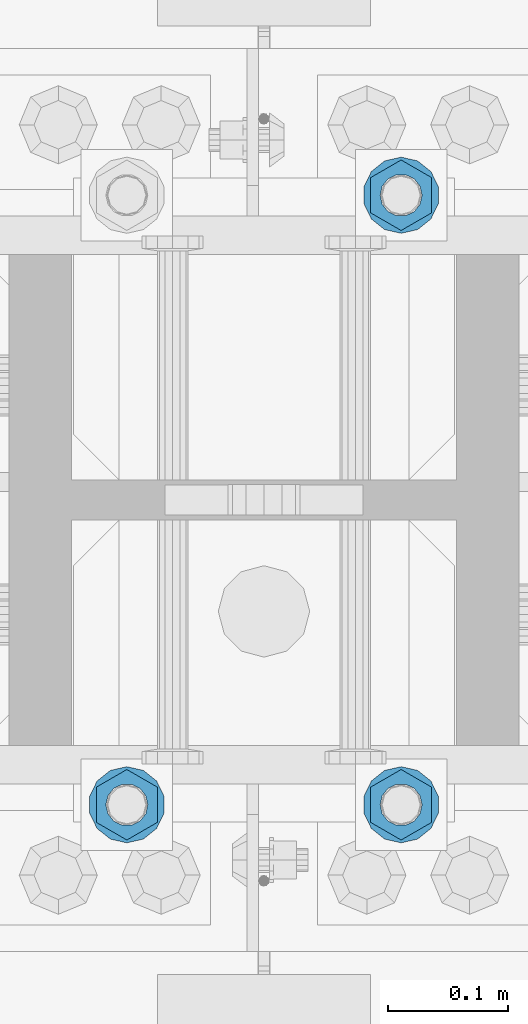
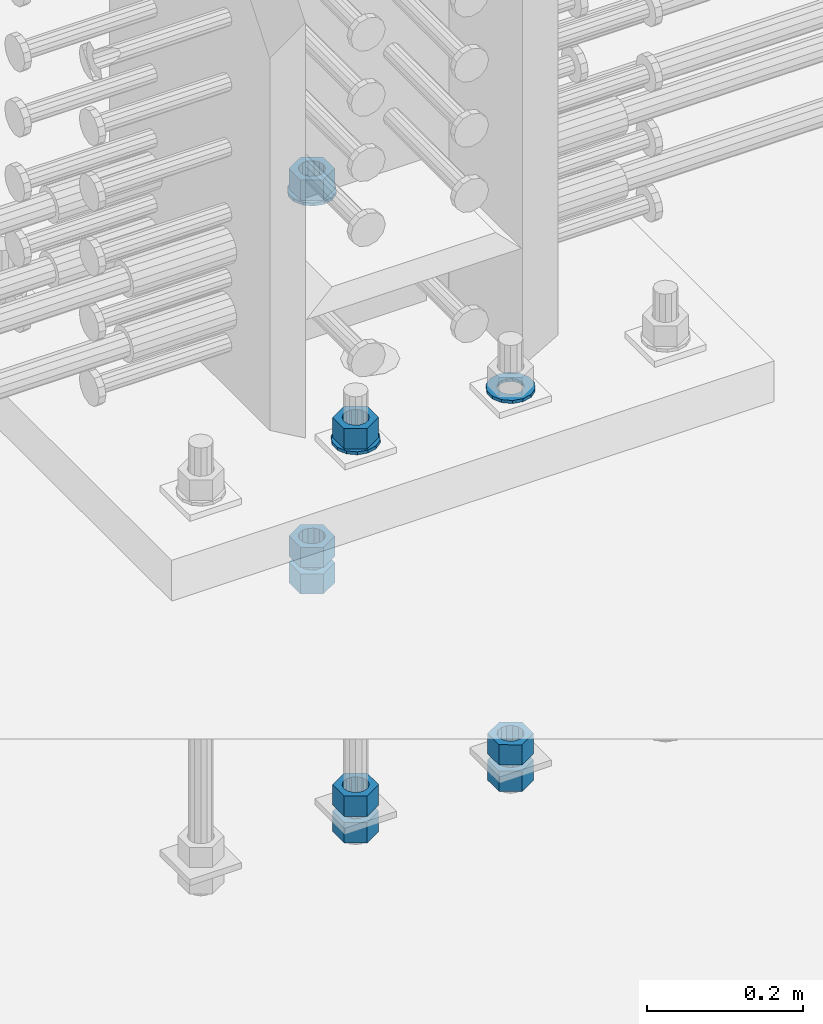
# One storey, part 1000 of 1763: 11 columns, 1 element without a shape of its own.
"""IFC2X3 building model written with IfcOpenShell, lengths in millimetres."""

from ifc_helpers import new_model, si_unit, frame, origin_with_axes, place, context, subcontext, project, spatial, faceted_brep, material, type_object, element, aggregate, save


model = new_model("IFC2X3")

# Units and contexts
model_context = context("Model", 3, precision=1e-05, world=origin_with_axes())
body_context = subcontext(model_context, "Body", "Model", "MODEL_VIEW")
ifc_project = project(units=[si_unit("LENGTHUNIT", "METRE", prefix="MILLI"), si_unit("AREAUNIT", "SQUARE_METRE"), si_unit("VOLUMEUNIT", "CUBIC_METRE"), si_unit("MASSUNIT", "GRAM", prefix="KILO"), si_unit("TIMEUNIT", "SECOND"), si_unit("PLANEANGLEUNIT", "RADIAN"), si_unit("SOLIDANGLEUNIT", "STERADIAN"), si_unit("THERMODYNAMICTEMPERATUREUNIT", "DEGREE_CELSIUS"), si_unit("LUMINOUSINTENSITYUNIT", "LUMEN")], contexts=[model_context])

# Site, building, storey
site_placement = place(None, origin_with_axes())
site = spatial("IfcSite", under=ifc_project, at=site_placement, CompositionType="ELEMENT")
building_placement = place(site_placement, origin_with_axes())
building = spatial("IfcBuilding", under=site, at=building_placement, Name="Undefined", CompositionType="ELEMENT")
storey_placement = place(building_placement, origin_with_axes())
storey = spatial("IfcBuildingStorey", under=building, at=storey_placement, Name="Undefined", CompositionType="ELEMENT", Elevation=0.0)

# Assembly, columns
assembly_placement = place(storey_placement, origin_with_axes())
assembly = element("IfcElementAssembly", 1, at=assembly_placement, inside=storey, Name="TEMPLATE", AssemblyPlace="NOTDEFINED", PredefinedType="RIGID_FRAME")
ifc_material_1 = material(Name="STEEL/A563")
column_type_1 = type_object("IfcColumnType", Name="1-1/4_HEAVY_HEX_NUT", PredefinedType="NOTDEFINED")
column_1_placement = place(assembly_placement, frame((-49288.1372736986, 203.200000000003, 3384.55), z_axis=(1.0, 0.0, 0.0), x_axis=(0.0, 0.0, -1.0)))
column_1 = element("IfcColumn", 2, at=column_1_placement, type_object=column_type_1, material=ifc_material_1, Name="NUT", ObjectType="1-1/4_HEAVY_HEX_NUT", context=body_context, shape_type="Brep", body=[
    faceted_brep([(0.0, -29.3700008392334, 0.0), (0.0, -14.6800003051758, -25.4300003051758), (31.75, -14.6800003051758, -25.4300003051758), (31.75, -29.3700008392334, 0.0), (0.0, 14.6800003051758, -25.4300003051758), (31.75, 14.6800003051758, -25.4300003051758), (0.0, 29.3700008392334, 0.0), (31.75, 29.3700008392334, 0.0), (0.0, 14.6800003051758, 25.4300003051758), (31.75, 14.6800003051758, 25.4300003051758), (0.0, -14.6800003051758, 25.4300003051758), (31.75, -14.6800003051758, 25.4300003051758), (0.0, 0.0, 17.4599990844727), (0.0, 7.57560968776022, 15.730915608714), (31.75, 7.57560968775942, 15.7309156087145), (31.75, 0.0, 17.4599990844727), (0.0, 13.6507769681037, 10.8861313696252), (31.75, 13.6507769681048, 10.8861313696314), (0.0, 17.0222404541215, 3.88521530314756), (31.75, 17.02224045412, 3.88521530315316), (0.0, 17.0222404541215, -3.88521530314756), (31.75, 17.02224045412, -3.88521530315332), (0.0, 13.6507769681037, -10.8861313696252), (31.75, 13.6507769681048, -10.8861313696316), (0.0, 7.57560968776022, -15.730915608714), (31.75, 7.57560968775942, -15.7309156087146), (0.0, 0.0, -17.4599990844727), (31.75, 0.0, -17.4599990844727), (0.0, -7.57560968776022, -15.730915608714), (31.75, -7.57560968775942, -15.7309156087145), (0.0, -13.6507769681037, -10.8861313696252), (31.75, -13.6507769681048, -10.8861313696314), (0.0, -17.0222404541215, -3.88521530314756), (31.75, -17.02224045412, -3.88521530315316), (0.0, -17.0222404541215, 3.88521530314756), (31.75, -17.02224045412, 3.88521530315332), (0.0, -13.6507769681037, 10.8861313696252), (31.75, -13.6507769681048, 10.8861313696316), (0.0, -7.57560968776022, 15.730915608714), (31.75, -7.57560968775942, 15.7309156087146)], [[[0, 1, 2, 3]], [[1, 4, 5, 2]], [[4, 6, 7, 5]], [[6, 8, 9, 7]], [[8, 10, 11, 9]], [[10, 0, 3, 11]], [[12, 13, 14, 15]], [[13, 16, 17, 14]], [[16, 18, 19, 17]], [[18, 20, 21, 19]], [[20, 22, 23, 21]], [[22, 24, 25, 23]], [[24, 26, 27, 25]], [[26, 28, 29, 27]], [[28, 30, 31, 29]], [[30, 32, 33, 31]], [[32, 34, 35, 33]], [[34, 36, 37, 35]], [[36, 38, 39, 37]], [[38, 12, 15, 39]], [[5, 7, 9, 11, 3, 2], [17, 19, 21, 23, 25, 27, 29, 31, 33, 35, 37, 39, 15, 14]], [[10, 8, 6, 4, 1, 0], [38, 36, 34, 32, 30, 28, 26, 24, 22, 20, 18, 16, 13, 12]]]),
])
column_2_placement = place(assembly_placement, frame((-49288.1372736986, 203.200000000003, 3343.275), z_axis=(1.0, 0.0, 0.0), x_axis=(0.0, 0.0, -1.0)))
column_2 = element("IfcColumn", 3, at=column_2_placement, type_object=column_type_1, material=ifc_material_1, Name="NUT", ObjectType="1-1/4_HEAVY_HEX_NUT", context=body_context, shape_type="Brep", body=[
    faceted_brep([(0.0, -29.3700008392334, 0.0), (0.0, -14.6800003051758, -25.4300003051758), (31.75, -14.6800003051758, -25.4300003051758), (31.75, -29.3700008392334, 0.0), (0.0, 14.6800003051758, -25.4300003051758), (31.75, 14.6800003051758, -25.4300003051758), (0.0, 29.3700008392334, 0.0), (31.75, 29.3700008392334, 0.0), (0.0, 14.6800003051758, 25.4300003051758), (31.75, 14.6800003051758, 25.4300003051758), (0.0, -14.6800003051758, 25.4300003051758), (31.75, -14.6800003051758, 25.4300003051758), (0.0, 0.0, 17.4599990844727), (0.0, 7.57560968776022, 15.730915608714), (31.75, 7.57560968775942, 15.7309156087145), (31.75, 0.0, 17.4599990844727), (0.0, 13.6507769681037, 10.8861313696252), (31.75, 13.6507769681048, 10.8861313696314), (0.0, 17.0222404541215, 3.88521530314756), (31.75, 17.02224045412, 3.88521530315316), (0.0, 17.0222404541215, -3.88521530314756), (31.75, 17.02224045412, -3.88521530315332), (0.0, 13.6507769681037, -10.8861313696252), (31.75, 13.6507769681048, -10.8861313696316), (0.0, 7.57560968776022, -15.730915608714), (31.75, 7.57560968775942, -15.7309156087146), (0.0, 0.0, -17.4599990844727), (31.75, 0.0, -17.4599990844727), (0.0, -7.57560968776022, -15.730915608714), (31.75, -7.57560968775942, -15.7309156087145), (0.0, -13.6507769681037, -10.8861313696252), (31.75, -13.6507769681048, -10.8861313696314), (0.0, -17.0222404541215, -3.88521530314756), (31.75, -17.02224045412, -3.88521530315316), (0.0, -17.0222404541215, 3.88521530314756), (31.75, -17.02224045412, 3.88521530315332), (0.0, -13.6507769681037, 10.8861313696252), (31.75, -13.6507769681048, 10.8861313696316), (0.0, -7.57560968776022, 15.730915608714), (31.75, -7.57560968775942, 15.7309156087146)], [[[0, 1, 2, 3]], [[1, 4, 5, 2]], [[4, 6, 7, 5]], [[6, 8, 9, 7]], [[8, 10, 11, 9]], [[10, 0, 3, 11]], [[12, 13, 14, 15]], [[13, 16, 17, 14]], [[16, 18, 19, 17]], [[18, 20, 21, 19]], [[20, 22, 23, 21]], [[22, 24, 25, 23]], [[24, 26, 27, 25]], [[26, 28, 29, 27]], [[28, 30, 31, 29]], [[30, 32, 33, 31]], [[32, 34, 35, 33]], [[34, 36, 37, 35]], [[36, 38, 39, 37]], [[38, 12, 15, 39]], [[5, 7, 9, 11, 3, 2], [17, 19, 21, 23, 25, 27, 29, 31, 33, 35, 37, 39, 15, 14]], [[10, 8, 6, 4, 1, 0], [38, 36, 34, 32, 30, 28, 26, 24, 22, 20, 18, 16, 13, 12]]]),
])
column_3_placement = place(assembly_placement, frame((-49288.1372736986, 711.200000000003, 3957.6375), z_axis=(-1.0, 0.0, 0.0), x_axis=(0.0, 0.0, -1.0)))
column_3 = element("IfcColumn", 4, at=column_3_placement, type_object=column_type_1, material=ifc_material_1, Name="NUT", ObjectType="1-1/4_HEAVY_HEX_NUT", context=body_context, shape_type="Brep", body=[
    faceted_brep([(0.0, -29.3700008392334, 0.0), (0.0, -14.6800003051758, -25.4300003051758), (31.75, -14.6800003051758, -25.4300003051758), (31.75, -29.3700008392334, 0.0), (0.0, 14.6800003051758, -25.4300003051758), (31.75, 14.6800003051758, -25.4300003051758), (0.0, 29.3700008392334, 0.0), (31.75, 29.3700008392334, 0.0), (0.0, 14.6800003051758, 25.4300003051758), (31.75, 14.6800003051758, 25.4300003051758), (0.0, -14.6800003051758, 25.4300003051758), (31.75, -14.6800003051758, 25.4300003051758), (0.0, 0.0, 17.4599990844727), (0.0, 7.57560968776022, 15.730915608714), (31.75, 7.57560968775942, 15.7309156087145), (31.75, 0.0, 17.4599990844727), (0.0, 13.6507769681037, 10.8861313696252), (31.75, 13.6507769681048, 10.8861313696314), (0.0, 17.0222404541215, 3.88521530314756), (31.75, 17.02224045412, 3.88521530315316), (0.0, 17.0222404541215, -3.88521530314756), (31.75, 17.02224045412, -3.88521530315332), (0.0, 13.6507769681037, -10.8861313696252), (31.75, 13.6507769681048, -10.8861313696316), (0.0, 7.57560968776022, -15.730915608714), (31.75, 7.57560968775942, -15.7309156087146), (0.0, 0.0, -17.4599990844727), (31.75, 0.0, -17.4599990844727), (0.0, -7.57560968776022, -15.730915608714), (31.75, -7.57560968775942, -15.7309156087145), (0.0, -13.6507769681037, -10.8861313696252), (31.75, -13.6507769681048, -10.8861313696314), (0.0, -17.0222404541215, -3.88521530314756), (31.75, -17.02224045412, -3.88521530315316), (0.0, -17.0222404541215, 3.88521530314756), (31.75, -17.02224045412, 3.88521530315332), (0.0, -13.6507769681037, 10.8861313696252), (31.75, -13.6507769681048, 10.8861313696316), (0.0, -7.57560968776022, 15.730915608714), (31.75, -7.57560968775942, 15.7309156087146)], [[[0, 1, 2, 3]], [[1, 4, 5, 2]], [[4, 6, 7, 5]], [[6, 8, 9, 7]], [[8, 10, 11, 9]], [[10, 0, 3, 11]], [[12, 13, 14, 15]], [[13, 16, 17, 14]], [[16, 18, 19, 17]], [[18, 20, 21, 19]], [[20, 22, 23, 21]], [[22, 24, 25, 23]], [[24, 26, 27, 25]], [[26, 28, 29, 27]], [[28, 30, 31, 29]], [[30, 32, 33, 31]], [[32, 34, 35, 33]], [[34, 36, 37, 35]], [[36, 38, 39, 37]], [[38, 12, 15, 39]], [[5, 7, 9, 11, 3, 2], [17, 19, 21, 23, 25, 27, 29, 31, 33, 35, 37, 39, 15, 14]], [[10, 8, 6, 4, 1, 0], [38, 36, 34, 32, 30, 28, 26, 24, 22, 20, 18, 16, 13, 12]]]),
])
column_4_placement = place(assembly_placement, frame((-49288.1372736986, 711.200000000003, 3384.55), z_axis=(-1.0, 0.0, 0.0), x_axis=(0.0, 0.0, -1.0)))
column_4 = element("IfcColumn", 5, at=column_4_placement, type_object=column_type_1, material=ifc_material_1, Name="NUT", ObjectType="1-1/4_HEAVY_HEX_NUT", context=body_context, shape_type="Brep", body=[
    faceted_brep([(0.0, -29.3700008392334, 0.0), (0.0, -14.6800003051758, -25.4300003051758), (31.75, -14.6800003051758, -25.4300003051758), (31.75, -29.3700008392334, 0.0), (0.0, 14.6800003051758, -25.4300003051758), (31.75, 14.6800003051758, -25.4300003051758), (0.0, 29.3700008392334, 0.0), (31.75, 29.3700008392334, 0.0), (0.0, 14.6800003051758, 25.4300003051758), (31.75, 14.6800003051758, 25.4300003051758), (0.0, -14.6800003051758, 25.4300003051758), (31.75, -14.6800003051758, 25.4300003051758), (0.0, 0.0, 17.4599990844727), (0.0, 7.57560968776022, 15.730915608714), (31.75, 7.57560968775942, 15.7309156087145), (31.75, 0.0, 17.4599990844727), (0.0, 13.6507769681037, 10.8861313696252), (31.75, 13.6507769681048, 10.8861313696314), (0.0, 17.0222404541215, 3.88521530314756), (31.75, 17.02224045412, 3.88521530315316), (0.0, 17.0222404541215, -3.88521530314756), (31.75, 17.02224045412, -3.88521530315332), (0.0, 13.6507769681037, -10.8861313696252), (31.75, 13.6507769681048, -10.8861313696316), (0.0, 7.57560968776022, -15.730915608714), (31.75, 7.57560968775942, -15.7309156087146), (0.0, 0.0, -17.4599990844727), (31.75, 0.0, -17.4599990844727), (0.0, -7.57560968776022, -15.730915608714), (31.75, -7.57560968775942, -15.7309156087145), (0.0, -13.6507769681037, -10.8861313696252), (31.75, -13.6507769681048, -10.8861313696314), (0.0, -17.0222404541215, -3.88521530314756), (31.75, -17.02224045412, -3.88521530315316), (0.0, -17.0222404541215, 3.88521530314756), (31.75, -17.02224045412, 3.88521530315332), (0.0, -13.6507769681037, 10.8861313696252), (31.75, -13.6507769681048, 10.8861313696316), (0.0, -7.57560968776022, 15.730915608714), (31.75, -7.57560968775942, 15.7309156087146)], [[[0, 1, 2, 3]], [[1, 4, 5, 2]], [[4, 6, 7, 5]], [[6, 8, 9, 7]], [[8, 10, 11, 9]], [[10, 0, 3, 11]], [[12, 13, 14, 15]], [[13, 16, 17, 14]], [[16, 18, 19, 17]], [[18, 20, 21, 19]], [[20, 22, 23, 21]], [[22, 24, 25, 23]], [[24, 26, 27, 25]], [[26, 28, 29, 27]], [[28, 30, 31, 29]], [[30, 32, 33, 31]], [[32, 34, 35, 33]], [[34, 36, 37, 35]], [[36, 38, 39, 37]], [[38, 12, 15, 39]], [[5, 7, 9, 11, 3, 2], [17, 19, 21, 23, 25, 27, 29, 31, 33, 35, 37, 39, 15, 14]], [[10, 8, 6, 4, 1, 0], [38, 36, 34, 32, 30, 28, 26, 24, 22, 20, 18, 16, 13, 12]]]),
])
column_5_placement = place(assembly_placement, frame((-49288.1372736986, 711.200000000003, 3343.275), z_axis=(-1.0, 0.0, 0.0), x_axis=(0.0, 0.0, -1.0)))
column_5 = element("IfcColumn", 6, at=column_5_placement, type_object=column_type_1, material=ifc_material_1, Name="NUT", ObjectType="1-1/4_HEAVY_HEX_NUT", context=body_context, shape_type="Brep", body=[
    faceted_brep([(0.0, -29.3700008392334, 0.0), (0.0, -14.6800003051758, -25.4300003051758), (31.75, -14.6800003051758, -25.4300003051758), (31.75, -29.3700008392334, 0.0), (0.0, 14.6800003051758, -25.4300003051758), (31.75, 14.6800003051758, -25.4300003051758), (0.0, 29.3700008392334, 0.0), (31.75, 29.3700008392334, 0.0), (0.0, 14.6800003051758, 25.4300003051758), (31.75, 14.6800003051758, 25.4300003051758), (0.0, -14.6800003051758, 25.4300003051758), (31.75, -14.6800003051758, 25.4300003051758), (0.0, 0.0, 17.4599990844727), (0.0, 7.57560968776022, 15.730915608714), (31.75, 7.57560968775942, 15.7309156087145), (31.75, 0.0, 17.4599990844727), (0.0, 13.6507769681037, 10.8861313696252), (31.75, 13.6507769681048, 10.8861313696314), (0.0, 17.0222404541215, 3.88521530314756), (31.75, 17.02224045412, 3.88521530315316), (0.0, 17.0222404541215, -3.88521530314756), (31.75, 17.02224045412, -3.88521530315332), (0.0, 13.6507769681037, -10.8861313696252), (31.75, 13.6507769681048, -10.8861313696316), (0.0, 7.57560968776022, -15.730915608714), (31.75, 7.57560968775942, -15.7309156087146), (0.0, 0.0, -17.4599990844727), (31.75, 0.0, -17.4599990844727), (0.0, -7.57560968776022, -15.730915608714), (31.75, -7.57560968775942, -15.7309156087145), (0.0, -13.6507769681037, -10.8861313696252), (31.75, -13.6507769681048, -10.8861313696314), (0.0, -17.0222404541215, -3.88521530314756), (31.75, -17.02224045412, -3.88521530315316), (0.0, -17.0222404541215, 3.88521530314756), (31.75, -17.02224045412, 3.88521530315332), (0.0, -13.6507769681037, 10.8861313696252), (31.75, -13.6507769681048, 10.8861313696316), (0.0, -7.57560968776022, 15.730915608714), (31.75, -7.57560968775942, 15.7309156087146)], [[[0, 1, 2, 3]], [[1, 4, 5, 2]], [[4, 6, 7, 5]], [[6, 8, 9, 7]], [[8, 10, 11, 9]], [[10, 0, 3, 11]], [[12, 13, 14, 15]], [[13, 16, 17, 14]], [[16, 18, 19, 17]], [[18, 20, 21, 19]], [[20, 22, 23, 21]], [[22, 24, 25, 23]], [[24, 26, 27, 25]], [[26, 28, 29, 27]], [[28, 30, 31, 29]], [[30, 32, 33, 31]], [[32, 34, 35, 33]], [[34, 36, 37, 35]], [[36, 38, 39, 37]], [[38, 12, 15, 39]], [[5, 7, 9, 11, 3, 2], [17, 19, 21, 23, 25, 27, 29, 31, 33, 35, 37, 39, 15, 14]], [[10, 8, 6, 4, 1, 0], [38, 36, 34, 32, 30, 28, 26, 24, 22, 20, 18, 16, 13, 12]]]),
])
column_6_placement = place(assembly_placement, frame((-49516.7372736986, 203.200000000003, 3957.6375), z_axis=(1.0, 0.0, 0.0), x_axis=(0.0, 0.0, -1.0)))
column_6 = element("IfcColumn", 7, at=column_6_placement, type_object=column_type_1, material=ifc_material_1, Name="NUT", ObjectType="1-1/4_HEAVY_HEX_NUT", context=body_context, shape_type="Brep", body=[
    faceted_brep([(0.0, -29.3700008392334, 0.0), (0.0, -14.6800003051758, -25.4300003051758), (31.75, -14.6800003051758, -25.4300003051758), (31.75, -29.3700008392334, 0.0), (0.0, 14.6800003051758, -25.4300003051758), (31.75, 14.6800003051758, -25.4300003051758), (0.0, 29.3700008392334, 0.0), (31.75, 29.3700008392334, 0.0), (0.0, 14.6800003051758, 25.4300003051758), (31.75, 14.6800003051758, 25.4300003051758), (0.0, -14.6800003051758, 25.4300003051758), (31.75, -14.6800003051758, 25.4300003051758), (0.0, 0.0, 17.4599990844727), (0.0, 7.57560968776022, 15.730915608714), (31.75, 7.57560968775942, 15.7309156087145), (31.75, 0.0, 17.4599990844727), (0.0, 13.6507769681037, 10.8861313696252), (31.75, 13.6507769681048, 10.8861313696314), (0.0, 17.0222404541215, 3.88521530314756), (31.75, 17.02224045412, 3.88521530315316), (0.0, 17.0222404541215, -3.88521530314756), (31.75, 17.02224045412, -3.88521530315332), (0.0, 13.6507769681037, -10.8861313696252), (31.75, 13.6507769681048, -10.8861313696316), (0.0, 7.57560968776022, -15.730915608714), (31.75, 7.57560968775942, -15.7309156087146), (0.0, 0.0, -17.4599990844727), (31.75, 0.0, -17.4599990844727), (0.0, -7.57560968776022, -15.730915608714), (31.75, -7.57560968775942, -15.7309156087145), (0.0, -13.6507769681037, -10.8861313696252), (31.75, -13.6507769681048, -10.8861313696314), (0.0, -17.0222404541215, -3.88521530314756), (31.75, -17.02224045412, -3.88521530315316), (0.0, -17.0222404541215, 3.88521530314756), (31.75, -17.02224045412, 3.88521530315332), (0.0, -13.6507769681037, 10.8861313696252), (31.75, -13.6507769681048, 10.8861313696316), (0.0, -7.57560968776022, 15.730915608714), (31.75, -7.57560968775942, 15.7309156087146)], [[[0, 1, 2, 3]], [[1, 4, 5, 2]], [[4, 6, 7, 5]], [[6, 8, 9, 7]], [[8, 10, 11, 9]], [[10, 0, 3, 11]], [[12, 13, 14, 15]], [[13, 16, 17, 14]], [[16, 18, 19, 17]], [[18, 20, 21, 19]], [[20, 22, 23, 21]], [[22, 24, 25, 23]], [[24, 26, 27, 25]], [[26, 28, 29, 27]], [[28, 30, 31, 29]], [[30, 32, 33, 31]], [[32, 34, 35, 33]], [[34, 36, 37, 35]], [[36, 38, 39, 37]], [[38, 12, 15, 39]], [[5, 7, 9, 11, 3, 2], [17, 19, 21, 23, 25, 27, 29, 31, 33, 35, 37, 39, 15, 14]], [[10, 8, 6, 4, 1, 0], [38, 36, 34, 32, 30, 28, 26, 24, 22, 20, 18, 16, 13, 12]]]),
])
column_7_placement = place(assembly_placement, frame((-49516.7372736986, 203.200000000003, 3384.55), z_axis=(1.0, 0.0, 0.0), x_axis=(0.0, 0.0, -1.0)))
column_7 = element("IfcColumn", 8, at=column_7_placement, type_object=column_type_1, material=ifc_material_1, Name="NUT", ObjectType="1-1/4_HEAVY_HEX_NUT", context=body_context, shape_type="Brep", body=[
    faceted_brep([(0.0, -29.3700008392334, 0.0), (0.0, -14.6800003051758, -25.4300003051758), (31.75, -14.6800003051758, -25.4300003051758), (31.75, -29.3700008392334, 0.0), (0.0, 14.6800003051758, -25.4300003051758), (31.75, 14.6800003051758, -25.4300003051758), (0.0, 29.3700008392334, 0.0), (31.75, 29.3700008392334, 0.0), (0.0, 14.6800003051758, 25.4300003051758), (31.75, 14.6800003051758, 25.4300003051758), (0.0, -14.6800003051758, 25.4300003051758), (31.75, -14.6800003051758, 25.4300003051758), (0.0, 0.0, 17.4599990844727), (0.0, 7.57560968776022, 15.730915608714), (31.75, 7.57560968775942, 15.7309156087145), (31.75, 0.0, 17.4599990844727), (0.0, 13.6507769681037, 10.8861313696252), (31.75, 13.6507769681048, 10.8861313696314), (0.0, 17.0222404541215, 3.88521530314756), (31.75, 17.02224045412, 3.88521530315316), (0.0, 17.0222404541215, -3.88521530314756), (31.75, 17.02224045412, -3.88521530315332), (0.0, 13.6507769681037, -10.8861313696252), (31.75, 13.6507769681048, -10.8861313696316), (0.0, 7.57560968776022, -15.730915608714), (31.75, 7.57560968775942, -15.7309156087146), (0.0, 0.0, -17.4599990844727), (31.75, 0.0, -17.4599990844727), (0.0, -7.57560968776022, -15.730915608714), (31.75, -7.57560968775942, -15.7309156087145), (0.0, -13.6507769681037, -10.8861313696252), (31.75, -13.6507769681048, -10.8861313696314), (0.0, -17.0222404541215, -3.88521530314756), (31.75, -17.02224045412, -3.88521530315316), (0.0, -17.0222404541215, 3.88521530314756), (31.75, -17.02224045412, 3.88521530315332), (0.0, -13.6507769681037, 10.8861313696252), (31.75, -13.6507769681048, 10.8861313696316), (0.0, -7.57560968776022, 15.730915608714), (31.75, -7.57560968775942, 15.7309156087146)], [[[0, 1, 2, 3]], [[1, 4, 5, 2]], [[4, 6, 7, 5]], [[6, 8, 9, 7]], [[8, 10, 11, 9]], [[10, 0, 3, 11]], [[12, 13, 14, 15]], [[13, 16, 17, 14]], [[16, 18, 19, 17]], [[18, 20, 21, 19]], [[20, 22, 23, 21]], [[22, 24, 25, 23]], [[24, 26, 27, 25]], [[26, 28, 29, 27]], [[28, 30, 31, 29]], [[30, 32, 33, 31]], [[32, 34, 35, 33]], [[34, 36, 37, 35]], [[36, 38, 39, 37]], [[38, 12, 15, 39]], [[5, 7, 9, 11, 3, 2], [17, 19, 21, 23, 25, 27, 29, 31, 33, 35, 37, 39, 15, 14]], [[10, 8, 6, 4, 1, 0], [38, 36, 34, 32, 30, 28, 26, 24, 22, 20, 18, 16, 13, 12]]]),
])
column_8_placement = place(assembly_placement, frame((-49516.7372736986, 203.200000000003, 3343.275), z_axis=(1.0, 0.0, 0.0), x_axis=(0.0, 0.0, -1.0)))
column_8 = element("IfcColumn", 9, at=column_8_placement, type_object=column_type_1, material=ifc_material_1, Name="NUT", ObjectType="1-1/4_HEAVY_HEX_NUT", context=body_context, shape_type="Brep", body=[
    faceted_brep([(0.0, -29.3700008392334, 0.0), (0.0, -14.6800003051758, -25.4300003051758), (31.75, -14.6800003051758, -25.4300003051758), (31.75, -29.3700008392334, 0.0), (0.0, 14.6800003051758, -25.4300003051758), (31.75, 14.6800003051758, -25.4300003051758), (0.0, 29.3700008392334, 0.0), (31.75, 29.3700008392334, 0.0), (0.0, 14.6800003051758, 25.4300003051758), (31.75, 14.6800003051758, 25.4300003051758), (0.0, -14.6800003051758, 25.4300003051758), (31.75, -14.6800003051758, 25.4300003051758), (0.0, 0.0, 17.4599990844727), (0.0, 7.57560968776022, 15.730915608714), (31.75, 7.57560968775942, 15.7309156087145), (31.75, 0.0, 17.4599990844727), (0.0, 13.6507769681037, 10.8861313696252), (31.75, 13.6507769681048, 10.8861313696314), (0.0, 17.0222404541215, 3.88521530314756), (31.75, 17.02224045412, 3.88521530315316), (0.0, 17.0222404541215, -3.88521530314756), (31.75, 17.02224045412, -3.88521530315332), (0.0, 13.6507769681037, -10.8861313696252), (31.75, 13.6507769681048, -10.8861313696316), (0.0, 7.57560968776022, -15.730915608714), (31.75, 7.57560968775942, -15.7309156087146), (0.0, 0.0, -17.4599990844727), (31.75, 0.0, -17.4599990844727), (0.0, -7.57560968776022, -15.730915608714), (31.75, -7.57560968775942, -15.7309156087145), (0.0, -13.6507769681037, -10.8861313696252), (31.75, -13.6507769681048, -10.8861313696314), (0.0, -17.0222404541215, -3.88521530314756), (31.75, -17.02224045412, -3.88521530315316), (0.0, -17.0222404541215, 3.88521530314756), (31.75, -17.02224045412, 3.88521530315332), (0.0, -13.6507769681037, 10.8861313696252), (31.75, -13.6507769681048, 10.8861313696316), (0.0, -7.57560968776022, 15.730915608714), (31.75, -7.57560968775942, 15.7309156087146)], [[[0, 1, 2, 3]], [[1, 4, 5, 2]], [[4, 6, 7, 5]], [[6, 8, 9, 7]], [[8, 10, 11, 9]], [[10, 0, 3, 11]], [[12, 13, 14, 15]], [[13, 16, 17, 14]], [[16, 18, 19, 17]], [[18, 20, 21, 19]], [[20, 22, 23, 21]], [[22, 24, 25, 23]], [[24, 26, 27, 25]], [[26, 28, 29, 27]], [[28, 30, 31, 29]], [[30, 32, 33, 31]], [[32, 34, 35, 33]], [[34, 36, 37, 35]], [[36, 38, 39, 37]], [[38, 12, 15, 39]], [[5, 7, 9, 11, 3, 2], [17, 19, 21, 23, 25, 27, 29, 31, 33, 35, 37, 39, 15, 14]], [[10, 8, 6, 4, 1, 0], [38, 36, 34, 32, 30, 28, 26, 24, 22, 20, 18, 16, 13, 12]]]),
])
ifc_material_2 = material(Name="STEEL/F436")
column_type_2 = type_object("IfcColumnType", Name="1-1/4_WASHER", PredefinedType="NOTDEFINED")
column_9_placement = place(assembly_placement, frame((-49288.1372736986, 203.200000000003, 3925.8875), z_axis=(1.0, 0.0, 0.0), x_axis=(0.0, 0.0, -1.0)))
column_9 = element("IfcColumn", 10, at=column_9_placement, type_object=column_type_2, material=ifc_material_2, Name="WASHER", ObjectType="1-1/4_WASHER", context=body_context, shape_type="Brep", body=[
    faceted_brep([(-4.54747350886464e-13, -31.7499999999964, 0.0), (0.0, -28.6057615559002, -13.7758087169827), (4.76249999999982, -28.6057615559002, -13.7758087169827), (4.76249999999982, -31.75, 0.0), (0.0, -19.795801209013, -24.8231495683602), (4.76249999999982, -19.795801209013, -24.8231495683602), (0.0, -7.06503965311276, -30.9539612117732), (4.76249999999982, -7.06503965311276, -30.9539612117732), (0.0, 7.06503965311276, -30.9539612117732), (4.76249999999982, 7.06503965311276, -30.9539612117732), (0.0, 19.7958012090166, -24.8231495683602), (4.76249999999982, 19.7958012090166, -24.8231495683602), (0.0, 28.6057615559039, -13.7758087169827), (4.76249999999982, 28.6057615559039, -13.7758087169827), (-5.91171556152403e-12, 31.7499999999891, 0.0), (4.76249999999982, 31.75, 0.0), (0.0, 28.6057615559002, 13.7758087169827), (4.76249999999982, 28.6057615559002, 13.7758087169827), (0.0, 19.795801209013, 24.8231495683602), (4.76249999999982, 19.795801209013, 24.8231495683602), (0.0, 7.06503965311276, 30.9539612117731), (4.76249999999982, 7.06503965311276, 30.9539612117731), (0.0, -7.06503965311276, 30.9539612117731), (4.76249999999982, -7.06503965311276, 30.9539612117731), (0.0, -19.7958012090166, 24.8231495683602), (4.76249999999982, -19.7958012090166, 24.8231495683602), (0.0, -28.6057615559039, 13.7758087169827), (4.76249999999982, -28.6057615559039, 13.7758087169827), (0.0, 0.0, 17.4599990844727), (0.0, 7.57560968776022, 15.730915608714), (4.76249999999982, 7.57560968775942, 15.7309156087145), (4.76249999999982, 0.0, 17.4599990844727), (0.0, 13.6507769681037, 10.8861313696252), (4.76249999999982, 13.6507769681048, 10.8861313696314), (0.0, 17.0222404541215, 3.88521530314756), (4.76249999999982, 17.02224045412, 3.88521530315316), (0.0, 17.0222404541215, -3.88521530314756), (4.76249999999982, 17.02224045412, -3.88521530315332), (0.0, 13.6507769681037, -10.8861313696252), (4.76249999999982, 13.6507769681048, -10.8861313696316), (0.0, 7.57560968776022, -15.730915608714), (4.76249999999982, 7.57560968775942, -15.7309156087146), (0.0, 0.0, -17.4599990844727), (4.76249999999982, 0.0, -17.4599990844727), (0.0, -7.57560968776022, -15.730915608714), (4.76249999999982, -7.57560968775942, -15.7309156087145), (0.0, -13.6507769681037, -10.8861313696252), (4.76249999999982, -13.6507769681048, -10.8861313696314), (0.0, -17.0222404541215, -3.88521530314756), (4.76249999999982, -17.02224045412, -3.88521530315316), (0.0, -17.0222404541215, 3.88521530314756), (4.76249999999982, -17.02224045412, 3.88521530315332), (0.0, -13.6507769681037, 10.8861313696252), (4.76249999999982, -13.6507769681048, 10.8861313696316), (0.0, -7.57560968776022, 15.730915608714), (4.76249999999982, -7.57560968775942, 15.7309156087146)], [[[0, 1, 2, 3]], [[1, 4, 5, 2]], [[4, 6, 7, 5]], [[6, 8, 9, 7]], [[8, 10, 11, 9]], [[10, 12, 13, 11]], [[12, 14, 15, 13]], [[14, 16, 17, 15]], [[16, 18, 19, 17]], [[18, 20, 21, 19]], [[20, 22, 23, 21]], [[22, 24, 25, 23]], [[24, 26, 27, 25]], [[26, 0, 3, 27]], [[28, 29, 30, 31]], [[29, 32, 33, 30]], [[32, 34, 35, 33]], [[34, 36, 37, 35]], [[36, 38, 39, 37]], [[38, 40, 41, 39]], [[40, 42, 43, 41]], [[42, 44, 45, 43]], [[44, 46, 47, 45]], [[46, 48, 49, 47]], [[48, 50, 51, 49]], [[50, 52, 53, 51]], [[52, 54, 55, 53]], [[54, 28, 31, 55]], [[5, 7, 9, 11, 13, 15, 17, 19, 21, 23, 25, 27, 3, 2], [33, 35, 37, 39, 41, 43, 45, 47, 49, 51, 53, 55, 31, 30]], [[26, 24, 22, 20, 18, 16, 14, 12, 10, 8, 6, 4, 1, 0], [54, 52, 50, 48, 46, 44, 42, 40, 38, 36, 34, 32, 29, 28]]]),
])
column_10_placement = place(assembly_placement, frame((-49288.1372736986, 711.200000000003, 3925.8875), z_axis=(-1.0, 0.0, 0.0), x_axis=(0.0, 0.0, -1.0)))
column_10 = element("IfcColumn", 11, at=column_10_placement, type_object=column_type_2, material=ifc_material_2, Name="WASHER", ObjectType="1-1/4_WASHER", context=body_context, shape_type="Brep", body=[
    faceted_brep([(-4.54747350886464e-13, -31.7499999999964, 0.0), (0.0, -28.6057615559002, -13.7758087169827), (4.76249999999982, -28.6057615559002, -13.7758087169827), (4.76249999999982, -31.75, 0.0), (0.0, -19.795801209013, -24.8231495683602), (4.76249999999982, -19.795801209013, -24.8231495683602), (0.0, -7.06503965311276, -30.9539612117732), (4.76249999999982, -7.06503965311276, -30.9539612117732), (0.0, 7.06503965311276, -30.9539612117732), (4.76249999999982, 7.06503965311276, -30.9539612117732), (0.0, 19.7958012090166, -24.8231495683602), (4.76249999999982, 19.7958012090166, -24.8231495683602), (0.0, 28.6057615559039, -13.7758087169827), (4.76249999999982, 28.6057615559039, -13.7758087169827), (-5.91171556152403e-12, 31.7499999999891, 0.0), (4.76249999999982, 31.75, 0.0), (0.0, 28.6057615559002, 13.7758087169827), (4.76249999999982, 28.6057615559002, 13.7758087169827), (0.0, 19.795801209013, 24.8231495683602), (4.76249999999982, 19.795801209013, 24.8231495683602), (0.0, 7.06503965311276, 30.9539612117731), (4.76249999999982, 7.06503965311276, 30.9539612117731), (0.0, -7.06503965311276, 30.9539612117731), (4.76249999999982, -7.06503965311276, 30.9539612117731), (0.0, -19.7958012090166, 24.8231495683602), (4.76249999999982, -19.7958012090166, 24.8231495683602), (0.0, -28.6057615559039, 13.7758087169827), (4.76249999999982, -28.6057615559039, 13.7758087169827), (0.0, 0.0, 17.4599990844727), (0.0, 7.57560968776022, 15.730915608714), (4.76249999999982, 7.57560968775942, 15.7309156087145), (4.76249999999982, 0.0, 17.4599990844727), (0.0, 13.6507769681037, 10.8861313696252), (4.76249999999982, 13.6507769681048, 10.8861313696314), (0.0, 17.0222404541215, 3.88521530314756), (4.76249999999982, 17.02224045412, 3.88521530315316), (0.0, 17.0222404541215, -3.88521530314756), (4.76249999999982, 17.02224045412, -3.88521530315332), (0.0, 13.6507769681037, -10.8861313696252), (4.76249999999982, 13.6507769681048, -10.8861313696316), (0.0, 7.57560968776022, -15.730915608714), (4.76249999999982, 7.57560968775942, -15.7309156087146), (0.0, 0.0, -17.4599990844727), (4.76249999999982, 0.0, -17.4599990844727), (0.0, -7.57560968776022, -15.730915608714), (4.76249999999982, -7.57560968775942, -15.7309156087145), (0.0, -13.6507769681037, -10.8861313696252), (4.76249999999982, -13.6507769681048, -10.8861313696314), (0.0, -17.0222404541215, -3.88521530314756), (4.76249999999982, -17.02224045412, -3.88521530315316), (0.0, -17.0222404541215, 3.88521530314756), (4.76249999999982, -17.02224045412, 3.88521530315332), (0.0, -13.6507769681037, 10.8861313696252), (4.76249999999982, -13.6507769681048, 10.8861313696316), (0.0, -7.57560968776022, 15.730915608714), (4.76249999999982, -7.57560968775942, 15.7309156087146)], [[[0, 1, 2, 3]], [[1, 4, 5, 2]], [[4, 6, 7, 5]], [[6, 8, 9, 7]], [[8, 10, 11, 9]], [[10, 12, 13, 11]], [[12, 14, 15, 13]], [[14, 16, 17, 15]], [[16, 18, 19, 17]], [[18, 20, 21, 19]], [[20, 22, 23, 21]], [[22, 24, 25, 23]], [[24, 26, 27, 25]], [[26, 0, 3, 27]], [[28, 29, 30, 31]], [[29, 32, 33, 30]], [[32, 34, 35, 33]], [[34, 36, 37, 35]], [[36, 38, 39, 37]], [[38, 40, 41, 39]], [[40, 42, 43, 41]], [[42, 44, 45, 43]], [[44, 46, 47, 45]], [[46, 48, 49, 47]], [[48, 50, 51, 49]], [[50, 52, 53, 51]], [[52, 54, 55, 53]], [[54, 28, 31, 55]], [[5, 7, 9, 11, 13, 15, 17, 19, 21, 23, 25, 27, 3, 2], [33, 35, 37, 39, 41, 43, 45, 47, 49, 51, 53, 55, 31, 30]], [[26, 24, 22, 20, 18, 16, 14, 12, 10, 8, 6, 4, 1, 0], [54, 52, 50, 48, 46, 44, 42, 40, 38, 36, 34, 32, 29, 28]]]),
])
column_11_placement = place(assembly_placement, frame((-49516.7372736986, 203.200000000003, 3925.8875), z_axis=(1.0, 0.0, 0.0), x_axis=(0.0, 0.0, -1.0)))
column_11 = element("IfcColumn", 12, at=column_11_placement, type_object=column_type_2, material=ifc_material_2, Name="WASHER", ObjectType="1-1/4_WASHER", context=body_context, shape_type="Brep", body=[
    faceted_brep([(-4.54747350886464e-13, -31.7499999999964, 0.0), (0.0, -28.6057615559002, -13.7758087169827), (4.76249999999982, -28.6057615559002, -13.7758087169827), (4.76249999999982, -31.75, 0.0), (0.0, -19.795801209013, -24.8231495683602), (4.76249999999982, -19.795801209013, -24.8231495683602), (0.0, -7.06503965311276, -30.9539612117732), (4.76249999999982, -7.06503965311276, -30.9539612117732), (0.0, 7.06503965311276, -30.9539612117732), (4.76249999999982, 7.06503965311276, -30.9539612117732), (0.0, 19.7958012090166, -24.8231495683602), (4.76249999999982, 19.7958012090166, -24.8231495683602), (0.0, 28.6057615559039, -13.7758087169827), (4.76249999999982, 28.6057615559039, -13.7758087169827), (-5.91171556152403e-12, 31.7499999999891, 0.0), (4.76249999999982, 31.75, 0.0), (0.0, 28.6057615559002, 13.7758087169827), (4.76249999999982, 28.6057615559002, 13.7758087169827), (0.0, 19.795801209013, 24.8231495683602), (4.76249999999982, 19.795801209013, 24.8231495683602), (0.0, 7.06503965311276, 30.9539612117731), (4.76249999999982, 7.06503965311276, 30.9539612117731), (0.0, -7.06503965311276, 30.9539612117731), (4.76249999999982, -7.06503965311276, 30.9539612117731), (0.0, -19.7958012090166, 24.8231495683602), (4.76249999999982, -19.7958012090166, 24.8231495683602), (0.0, -28.6057615559039, 13.7758087169827), (4.76249999999982, -28.6057615559039, 13.7758087169827), (0.0, 0.0, 17.4599990844727), (0.0, 7.57560968776022, 15.730915608714), (4.76249999999982, 7.57560968775942, 15.7309156087145), (4.76249999999982, 0.0, 17.4599990844727), (0.0, 13.6507769681037, 10.8861313696252), (4.76249999999982, 13.6507769681048, 10.8861313696314), (0.0, 17.0222404541215, 3.88521530314756), (4.76249999999982, 17.02224045412, 3.88521530315316), (0.0, 17.0222404541215, -3.88521530314756), (4.76249999999982, 17.02224045412, -3.88521530315332), (0.0, 13.6507769681037, -10.8861313696252), (4.76249999999982, 13.6507769681048, -10.8861313696316), (0.0, 7.57560968776022, -15.730915608714), (4.76249999999982, 7.57560968775942, -15.7309156087146), (0.0, 0.0, -17.4599990844727), (4.76249999999982, 0.0, -17.4599990844727), (0.0, -7.57560968776022, -15.730915608714), (4.76249999999982, -7.57560968775942, -15.7309156087145), (0.0, -13.6507769681037, -10.8861313696252), (4.76249999999982, -13.6507769681048, -10.8861313696314), (0.0, -17.0222404541215, -3.88521530314756), (4.76249999999982, -17.02224045412, -3.88521530315316), (0.0, -17.0222404541215, 3.88521530314756), (4.76249999999982, -17.02224045412, 3.88521530315332), (0.0, -13.6507769681037, 10.8861313696252), (4.76249999999982, -13.6507769681048, 10.8861313696316), (0.0, -7.57560968776022, 15.730915608714), (4.76249999999982, -7.57560968775942, 15.7309156087146)], [[[0, 1, 2, 3]], [[1, 4, 5, 2]], [[4, 6, 7, 5]], [[6, 8, 9, 7]], [[8, 10, 11, 9]], [[10, 12, 13, 11]], [[12, 14, 15, 13]], [[14, 16, 17, 15]], [[16, 18, 19, 17]], [[18, 20, 21, 19]], [[20, 22, 23, 21]], [[22, 24, 25, 23]], [[24, 26, 27, 25]], [[26, 0, 3, 27]], [[28, 29, 30, 31]], [[29, 32, 33, 30]], [[32, 34, 35, 33]], [[34, 36, 37, 35]], [[36, 38, 39, 37]], [[38, 40, 41, 39]], [[40, 42, 43, 41]], [[42, 44, 45, 43]], [[44, 46, 47, 45]], [[46, 48, 49, 47]], [[48, 50, 51, 49]], [[50, 52, 53, 51]], [[52, 54, 55, 53]], [[54, 28, 31, 55]], [[5, 7, 9, 11, 13, 15, 17, 19, 21, 23, 25, 27, 3, 2], [33, 35, 37, 39, 41, 43, 45, 47, 49, 51, 53, 55, 31, 30]], [[26, 24, 22, 20, 18, 16, 14, 12, 10, 8, 6, 4, 1, 0], [54, 52, 50, 48, 46, 44, 42, 40, 38, 36, 34, 32, 29, 28]]]),
])
aggregate(assembly, [column_9, column_1, column_2, column_3, column_10, column_4, column_5, column_6, column_11, column_7, column_8])

save(model, "model.ifc")
